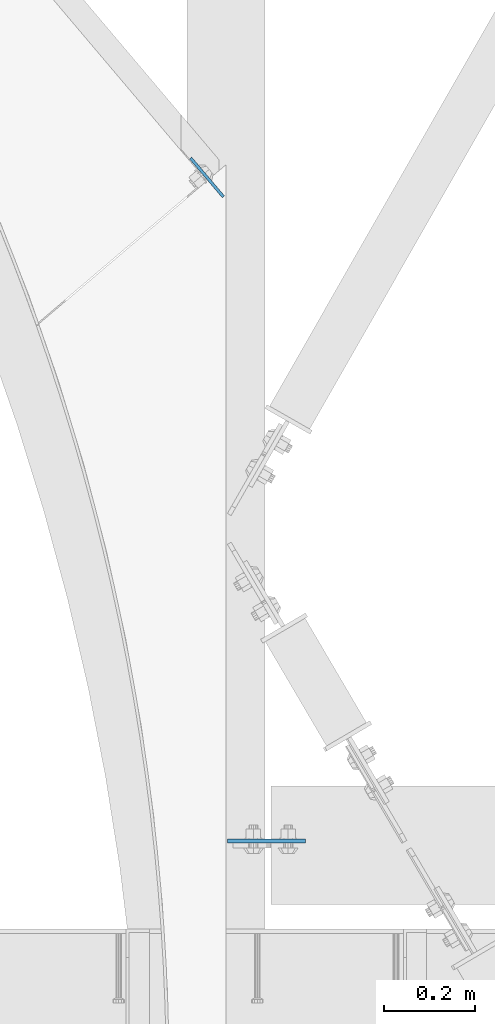
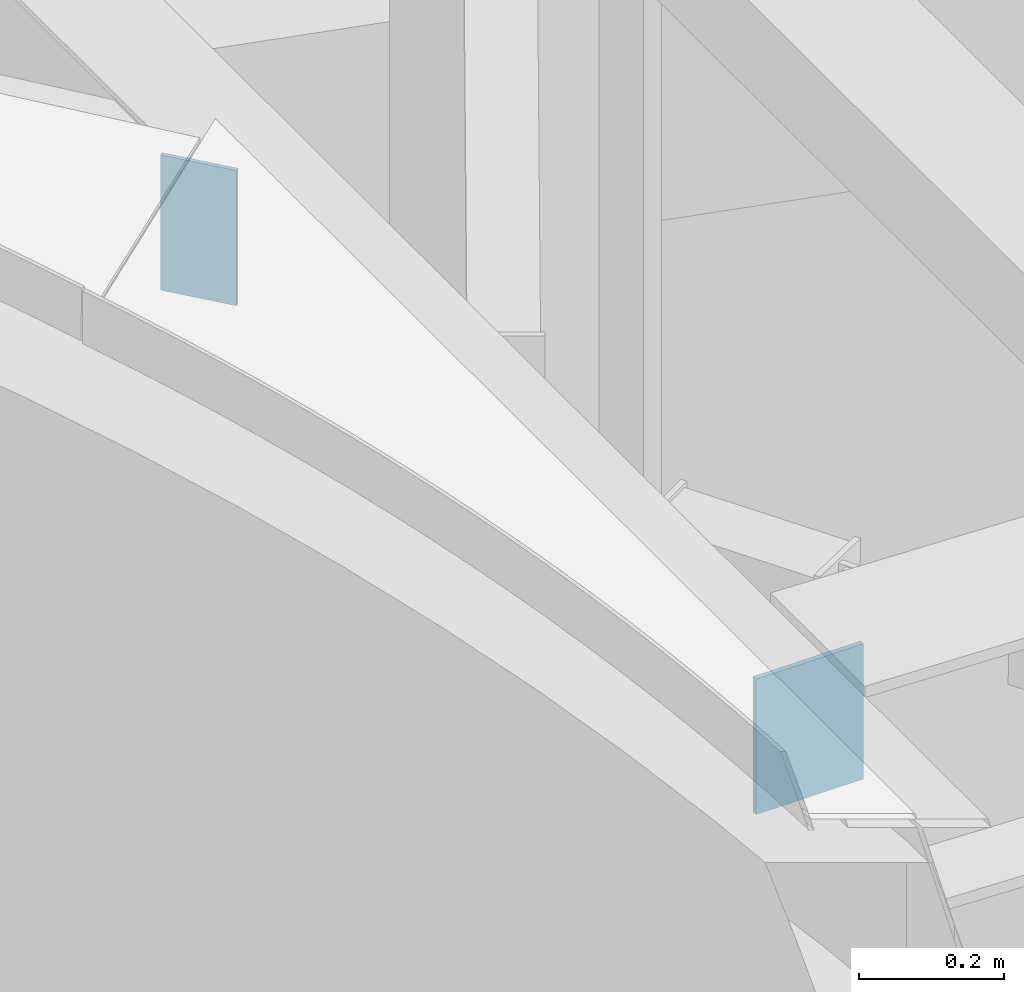
# One storey, part 1644 of 1763: 2 plates, 1 element without a shape of its own.
"""IFC2X3 building model written with IfcOpenShell, lengths in millimetres."""

from ifc_helpers import new_model, si_unit, frame, origin_with_axes, place, context, subcontext, project, spatial, faceted_brep, material, type_object, element, aggregate, save


model = new_model("IFC2X3")

# Units and contexts
model_context = context("Model", 3, precision=1e-05, world=origin_with_axes())
body_context = subcontext(model_context, "Body", "Model", "MODEL_VIEW")
ifc_project = project(units=[si_unit("LENGTHUNIT", "METRE", prefix="MILLI"), si_unit("AREAUNIT", "SQUARE_METRE"), si_unit("VOLUMEUNIT", "CUBIC_METRE"), si_unit("MASSUNIT", "GRAM", prefix="KILO"), si_unit("TIMEUNIT", "SECOND"), si_unit("PLANEANGLEUNIT", "RADIAN"), si_unit("SOLIDANGLEUNIT", "STERADIAN"), si_unit("THERMODYNAMICTEMPERATUREUNIT", "DEGREE_CELSIUS"), si_unit("LUMINOUSINTENSITYUNIT", "LUMEN")], contexts=[model_context])

# Site, building, storey
site_placement = place(None, origin_with_axes())
site = spatial("IfcSite", under=ifc_project, at=site_placement, CompositionType="ELEMENT")
building_placement = place(site_placement, origin_with_axes())
building = spatial("IfcBuilding", under=site, at=building_placement, Name="Undefined", CompositionType="ELEMENT")
storey_placement = place(building_placement, origin_with_axes())
storey = spatial("IfcBuildingStorey", under=building, at=storey_placement, Name="Undefined", CompositionType="ELEMENT", Elevation=0.0)

# Assembly, plates
assembly_placement = place(storey_placement, origin_with_axes())
assembly = element("IfcElementAssembly", 1, at=assembly_placement, inside=storey, Name="BEAM", AssemblyPlace="NOTDEFINED", PredefinedType="RIGID_FRAME")
ifc_material = material(Name="STEEL/A36")
plate_type_1 = type_object("IfcPlateType", PredefinedType="NOTDEFINED")
plate_1_placement = place(assembly_placement, frame((-41335.3632217719, 54187.7252499993, 12457.2073783165), z_axis=(1.0, 0.0, 0.0), x_axis=(0.0, 0.0, -1.0)))
plate_1 = element("IfcPlate", 2, at=plate_1_placement, type_object=plate_type_1, material=ifc_material, Name="PLATE", context=body_context, shape_type="Brep", body=[
    faceted_brep([(0.0, -3.96900000000096, 0.0), (0.0, -3.96899999999732, 171.449996948242), (0.0, 3.96899999999732, 171.449996948242), (0.0, 3.96900000000096, 0.0), (228.600006103516, -3.96899999999732, 171.449996948242), (228.600006103516, 3.96899999999732, 171.449996948242), (228.600006103516, -3.96900000000096, 0.0), (228.600006103516, 3.96900000000096, 0.0)], [[[0, 1, 2, 3]], [[1, 4, 5, 2]], [[4, 6, 7, 5]], [[6, 0, 3, 7]], [[5, 7, 3, 2]], [[6, 4, 1, 0]]]),
])
plate_type_2 = type_object("IfcPlateType", PredefinedType="NOTDEFINED")
plate_2_placement = place(assembly_placement, frame((-41344.1372338682, 55603.7027345627, 12460.3089971537), z_axis=(-0.645845215052767, 0.763468374062374, 7.63473508413882e-10), x_axis=(0.0, 0.0, -1.0)))
plate_2 = element("IfcPlate", 3, at=plate_2_placement, type_object=plate_type_2, material=ifc_material, Name="PLATE", context=body_context, shape_type="Brep", body=[
    faceted_brep([(1.81898940354586e-12, -3.17500000000291, 0.0), (-6.91215973347425e-11, -3.174999999791, 111.739151001035), (-6.91215973347425e-11, 3.17500000021482, 111.73915100102), (-1.81898940354586e-12, 3.17499999997381, 0.0), (228.600006103461, -3.17499999931988, 111.739151000482), (228.600006103461, 3.17500000067866, 111.739151000482), (228.600006103516, -3.17500000001019, -7.27595761418343e-12), (228.600006103516, 3.17499999999563, -7.27595761418343e-12)], [[[0, 1, 2, 3]], [[1, 4, 5, 2]], [[4, 6, 7, 5]], [[6, 0, 3, 7]], [[5, 7, 3, 2]], [[6, 4, 1, 0]]]),
])
aggregate(assembly, [plate_1, plate_2])

save(model, "model.ifc")
